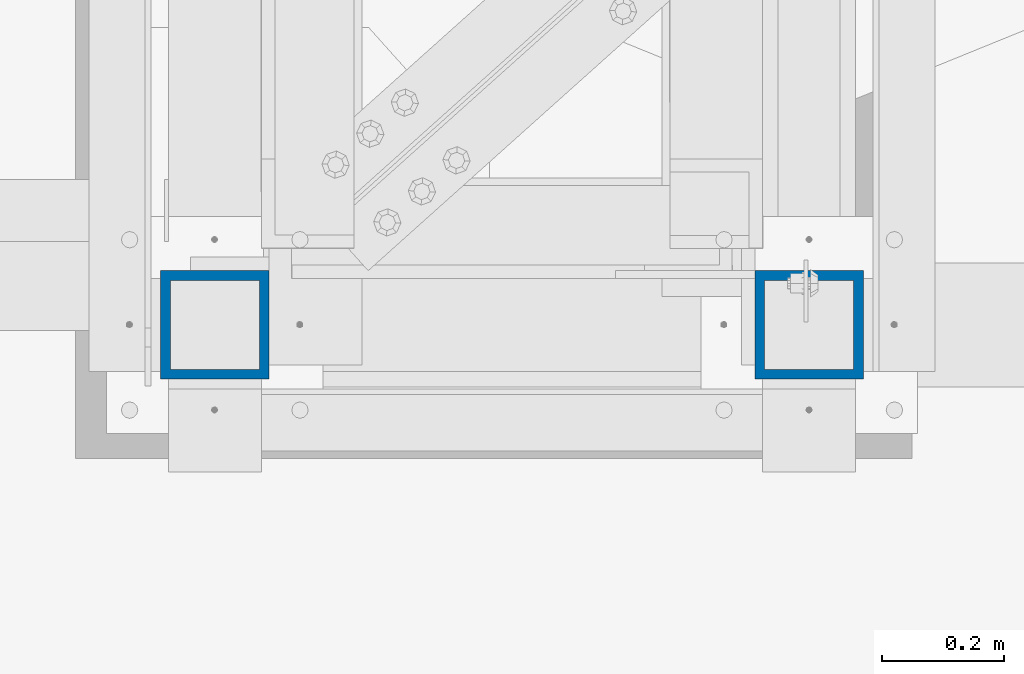
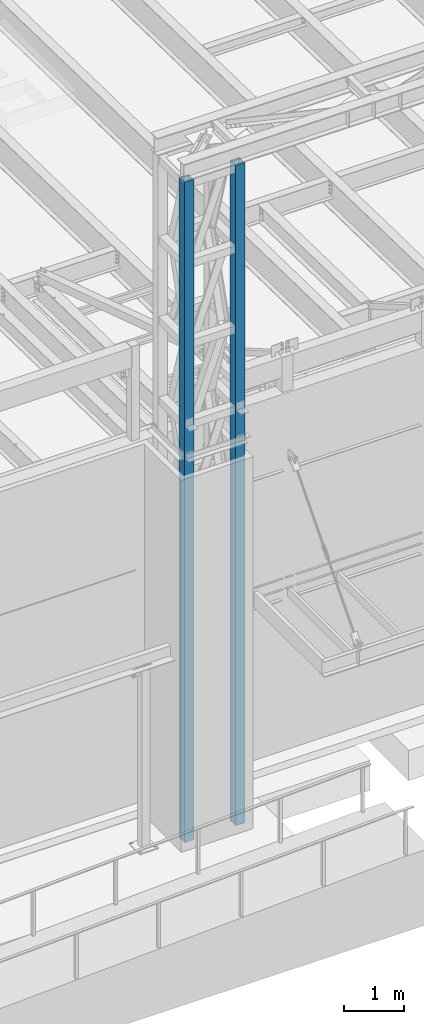
# One storey, part 889 of 1763: 2 columns, 1 element without a shape of its own.
"""IFC2X3 building model written with IfcOpenShell, lengths in millimetres."""

import ifcopenshell
import ifcopenshell.guid

model = None  # the IFC model being written
_history = None  # IfcOwnerHistory: only IFC2X3 demands one
_inside = {}  # id of a spatial element -> (the spatial element, [elements in it])
_under = {}  # id of a project, library or spatial element -> (it, [spatial elements below it])
_declared = {}  # id of a project -> (the project, [libraries it declares])
_typed = {}  # id of a type object -> (the type object, [elements of that type])
_made_of = {}  # id of a material, layer set ... -> (it, [elements and type objects made of it])


def new_model(schema):
    """Start an empty IFC model of exactly this schema.

    Asked for "IFC4X3", IfcOpenShell would pick the latest addendum, in which some entities
    have other attributes; the version numbers below select the first issue.
    IFC2X3 requires an IfcOwnerHistory on every rooted entity: one is made here for all.
    """
    global model, _history
    if schema == "IFC4X3":
        model = ifcopenshell.file(schema_version=(4, 3, 0, 0))
    else:
        model = ifcopenshell.file(schema=schema)
    _inside.clear()
    _under.clear()
    _declared.clear()
    _typed.clear()
    _made_of.clear()
    _history = None
    if model.schema == "IFC2X3":
        org = make("IfcOrganization", Name="unknown")
        user = make(
            "IfcPersonAndOrganization",
            ThePerson=make("IfcPerson", FamilyName="unknown"),
            TheOrganization=org,
        )
        app = make(
            "IfcApplication",
            ApplicationDeveloper=org,
            Version="unknown",
            ApplicationFullName="unknown",
            ApplicationIdentifier="unknown",
        )
        _history = make(
            "IfcOwnerHistory",
            OwningUser=user,
            OwningApplication=app,
            ChangeAction="ADDED",
            CreationDate=0,
        )
    return model


def make(cls, **values):
    """One entity of the class cls with the attributes given. An attribute that is None is left unset."""
    return model.create_entity(
        cls, **{name: value for name, value in values.items() if value is not None}
    )


def rooted(cls, **values):
    """An entity with a GlobalId (a new one), such as an element, a storey or a relation."""
    return make(cls, GlobalId=ifcopenshell.guid.new(), OwnerHistory=_history, **values)


def si_unit(unit_type, name, prefix=None):
    """IfcSIUnit, for example si_unit("LENGTHUNIT", "METRE", prefix="MILLI")."""
    return make("IfcSIUnit", UnitType=unit_type, Prefix=prefix, Name=name)


def assignment(units):
    """IfcUnitAssignment: the units of a project."""
    return None if units is None else make("IfcUnitAssignment", Units=units)


def point(xyz):
    """IfcCartesianPoint."""
    return None if xyz is None else make("IfcCartesianPoint", Coordinates=xyz)


def direction(xyz):
    """IfcDirection."""
    return None if xyz is None else make("IfcDirection", DirectionRatios=xyz)


def frame(location, z_axis=None, x_axis=None):
    """IfcAxis2Placement3D, a coordinate frame: its origin and axes. An axis left out is left unset."""
    return make(
        "IfcAxis2Placement3D",
        Location=point(location),
        Axis=direction(z_axis),
        RefDirection=direction(x_axis),
    )


def origin_with_axes():
    """The frame at (0, 0, 0) with the z axis (0, 0, 1) and the x axis (1, 0, 0) written out."""
    return frame((0.0, 0.0, 0.0), z_axis=(0.0, 0.0, 1.0), x_axis=(1.0, 0.0, 0.0))


def place(relative_to, where):
    """IfcLocalPlacement: puts the frame where relative to a parent placement (None: the world)."""
    return make(
        "IfcLocalPlacement", PlacementRelTo=relative_to, RelativePlacement=where
    )


def context(
    kind, dimensions, precision=None, world=None, true_north=None, identifier=None
):
    """IfcGeometricRepresentationContext, for example the 3D "Model" context."""
    return make(
        "IfcGeometricRepresentationContext",
        ContextIdentifier=identifier,
        ContextType=kind,
        CoordinateSpaceDimension=dimensions,
        Precision=precision,
        WorldCoordinateSystem=world,
        TrueNorth=true_north,
    )


def subcontext(parent, identifier, kind, view, scale=None):
    """IfcGeometricRepresentationSubContext, for example "Body" below "Model"."""
    return make(
        "IfcGeometricRepresentationSubContext",
        ContextIdentifier=identifier,
        ContextType=kind,
        ParentContext=parent,
        TargetScale=scale,
        TargetView=view,
    )


def project(units=None, contexts=None):
    """IfcProject with its units and contexts."""
    return rooted(
        "IfcProject",
        Name="project",
        RepresentationContexts=contexts,
        UnitsInContext=assignment(units),
    )


def spatial(cls, under=None, at=None, **own):
    """A site, building, storey or space (cls), placed at a placement, below another one or the project."""
    s = rooted(cls, ObjectPlacement=at, **own)
    if under is not None:
        _under.setdefault(under.id(), (under, []))[1].append(s)
    return s


def faces_of(points, faces, orient=None, outer=None):
    """IfcFace entities. A face is a list of loops; a loop is a list of indices into points, from 0.

    orient and outer hold one flag for each loop. By default every Orientation is true, the
    first loop of a face is its IfcFaceOuterBound and the others are IfcFaceBound.
    """
    made = []
    for i, loops in enumerate(faces):
        bounds = []
        for j, loop in enumerate(loops):
            is_outer = j == 0 if outer is None else outer[i][j]
            bounds.append(
                make(
                    "IfcFaceOuterBound" if is_outer else "IfcFaceBound",
                    Bound=make("IfcPolyLoop", Polygon=[points[k] for k in loop]),
                    Orientation=True if orient is None else orient[i][j],
                )
            )
        made.append(make("IfcFace", Bounds=bounds))
    return made


def faceted_brep(points, faces, orient=None, outer=None, voids=None):
    """IfcFacetedBrep: a solid bounded by flat faces; with voids (closed shells), ...WithVoids."""
    shared = [point(p) for p in points]
    hull = make("IfcClosedShell", CfsFaces=faces_of(shared, faces, orient, outer))
    if voids is None:
        return make("IfcFacetedBrep", Outer=hull)
    return make(
        "IfcFacetedBrepWithVoids",
        Outer=hull,
        Voids=[
            make(cls, CfsFaces=faces_of(shared, fs, o, b)) for cls, fs, o, b in voids
        ],
    )


def shape(context_of_items, identifier, shape_type, items):
    """IfcShapeRepresentation: the items that make up one representation, for example the "Body"."""
    return make(
        "IfcShapeRepresentation",
        ContextOfItems=context_of_items,
        RepresentationIdentifier=identifier,
        RepresentationType=shape_type,
        Items=items,
    )


def material(Name=None, Category=None):
    """IfcMaterial."""
    return make("IfcMaterial", Name=Name, Category=Category)


def made_of(thing, what):
    """Note that an element or type object is made of a material, layer set ...; save() writes the relation."""
    if what is not None:
        _made_of.setdefault(what.id(), (what, []))[1].append(thing)
    return thing


def type_object(cls, material=None, **own):
    """A type object (cls), such as IfcWallType, which elements share."""
    return made_of(rooted(cls, **own), material)


def element(
    cls,
    number,
    at=None,
    inside=None,
    cuts=None,
    type_object=None,
    material=None,
    context=None,
    identifier="Body",
    shape_type=None,
    held_by="IfcProductDefinitionShape",
    body=None,
    shapes=None,
    **own,
):
    """One element of the class cls, such as IfcWall. Its Tag is "e" and its number.

    at: its placement. inside: the storey or other place that contains it. cuts: it is an
    opening in that element (IfcRelVoidsElement). A single representation is given by context,
    identifier, shape_type and body (its items); several are given by shapes. held_by: the class
    of the entity that holds the representations. save() writes the other relations.
    """
    e = rooted(cls, Tag="e%d" % number, ObjectPlacement=at, **own)
    if body is not None:
        shapes = [shape(context, identifier, shape_type, body)]
    if shapes is not None:
        e.Representation = make(held_by, Representations=shapes)
    if inside is not None:
        _inside.setdefault(inside.id(), (inside, []))[1].append(e)
    if cuts is not None:
        rooted(
            "IfcRelVoidsElement", RelatingBuildingElement=cuts, RelatedOpeningElement=e
        )
    if type_object is not None:
        _typed.setdefault(type_object.id(), (type_object, []))[1].append(e)
    return made_of(e, material)


def aggregate(whole, parts):
    """IfcRelAggregates: a whole, such as a stair, and the parts it consists of."""
    return rooted("IfcRelAggregates", RelatingObject=whole, RelatedObjects=parts)


def save(model, path):
    """Write the relations noted so far, then the file.

    IfcRelAggregates (storeys below a building ...), IfcRelContainedInSpatialStructure (elements
    in a storey), IfcRelDefinesByType, IfcRelAssociatesMaterial and IfcRelDeclares: one each for
    every whole, place, type object, material and project.
    """
    for whole, parts in _under.values():
        aggregate(whole, parts)
    for where, things in _inside.values():
        rooted(
            "IfcRelContainedInSpatialStructure",
            RelatedElements=things,
            RelatingStructure=where,
        )
    for kind, things in _typed.values():
        rooted("IfcRelDefinesByType", RelatedObjects=things, RelatingType=kind)
    for what, things in _made_of.values():
        rooted("IfcRelAssociatesMaterial", RelatedObjects=things, RelatingMaterial=what)
    for by, libraries in _declared.values():
        rooted("IfcRelDeclares", RelatingContext=by, RelatedDefinitions=libraries)
    model.write(path)


model = new_model("IFC2X3")

# Units and contexts
model_context = context("Model", 3, precision=1e-05, world=origin_with_axes())
body_context = subcontext(model_context, "Body", "Model", "MODEL_VIEW")
ifc_project = project(units=[si_unit("LENGTHUNIT", "METRE", prefix="MILLI"), si_unit("AREAUNIT", "SQUARE_METRE"), si_unit("VOLUMEUNIT", "CUBIC_METRE"), si_unit("MASSUNIT", "GRAM", prefix="KILO"), si_unit("TIMEUNIT", "SECOND"), si_unit("PLANEANGLEUNIT", "RADIAN"), si_unit("SOLIDANGLEUNIT", "STERADIAN"), si_unit("THERMODYNAMICTEMPERATUREUNIT", "DEGREE_CELSIUS"), si_unit("LUMINOUSINTENSITYUNIT", "LUMEN")], contexts=[model_context])

# Site, building, storey
site_placement = place(None, origin_with_axes())
site = spatial("IfcSite", under=ifc_project, at=site_placement, CompositionType="ELEMENT")
building_placement = place(site_placement, origin_with_axes())
building = spatial("IfcBuilding", under=site, at=building_placement, Name="Undefined", CompositionType="ELEMENT")
storey_placement = place(building_placement, origin_with_axes())
storey = spatial("IfcBuildingStorey", under=building, at=storey_placement, Name="Undefined", CompositionType="ELEMENT", Elevation=0.0)

# Assembly, columns
assembly_placement = place(storey_placement, origin_with_axes())
assembly = element("IfcElementAssembly", 1, at=assembly_placement, inside=storey, Name="FRAME", AssemblyPlace="NOTDEFINED", PredefinedType="RIGID_FRAME")
ifc_material = material()
column_type = type_object("IfcColumnType", Name="HSS7X7X5/8", PredefinedType="NOTDEFINED")
column_1_placement = place(assembly_placement, frame((-63210.5025957005, -15452.7273151462, 5029.2), z_axis=(0.0, 1.0, 0.0), x_axis=(0.0, 0.0, 1.0)))
column_1 = element("IfcColumn", 2, at=column_1_placement, type_object=column_type, material=ifc_material, Name="COLUMN", ObjectType="HSS7X7X5/8", context=body_context, shape_type="Brep", body=[
    faceted_brep([(63.5000000000009, 73.0250000000015, -73.0249999999996), (63.5000000000009, -73.0250000000015, -73.0249999999996), (13420.725, -73.0250000000015, -73.0249999999996), (13420.725, 73.0250000000015, -73.0249999999996), (63.5000000000009, -73.0250000000015, 73.0249999999996), (13420.725, -73.0250000000015, 73.0249999999996), (63.5000000000009, 73.0250000000015, 73.0249999999996), (13420.725, 73.0250000000015, 73.0249999999996), (63.5000000000009, 88.9000000000015, -88.8999999999996), (63.5000000000009, 88.9000000000015, 88.8999999999996), (13420.725, 88.9000000000015, 88.8999999999996), (13420.725, 88.9000000000015, -88.8999999999996), (63.5000000000009, -88.9000000000015, 88.8999999999996), (13420.725, -88.9000000000015, 88.8999999999996), (63.5000000000009, -88.9000000000015, -88.8999999999996), (13420.725, -88.9000000000015, -88.8999999999996)], [[[0, 1, 2, 3]], [[1, 4, 5, 2]], [[4, 6, 7, 5]], [[6, 0, 3, 7]], [[8, 9, 10, 11]], [[9, 12, 13, 10]], [[12, 14, 15, 13]], [[14, 8, 11, 15]], [[13, 15, 11, 10], [5, 7, 3, 2]], [[14, 12, 9, 8], [6, 4, 1, 0]]]),
])
column_2_placement = place(assembly_placement, frame((-64185.2277910131, -15452.7273151462, 5029.2), z_axis=(0.0, 1.0, 0.0), x_axis=(0.0, 0.0, 1.0)))
column_2 = element("IfcColumn", 3, at=column_2_placement, type_object=column_type, material=ifc_material, Name="FRAME", ObjectType="HSS7X7X5/8", context=body_context, shape_type="Brep", body=[
    faceted_brep([(63.5000000000009, 73.0250000000015, -73.0249999999996), (63.5000000000009, -73.0250000000015, -73.0249999999996), (13420.725, -73.0250000000015, -73.0249999999996), (13420.725, 73.0250000000015, -73.0249999999996), (63.5000000000009, -73.0250000000015, 73.0249999999996), (13420.725, -73.0250000000015, 73.0249999999996), (63.5000000000009, 73.0250000000015, 73.0249999999996), (13420.725, 73.0250000000015, 73.0249999999996), (63.5000000000009, 88.9000000000015, -88.8999999999996), (63.5000000000009, 88.9000000000015, 88.8999999999996), (13420.725, 88.9000000000015, 88.8999999999996), (13420.725, 88.9000000000015, -88.8999999999996), (63.5000000000009, -88.9000000000015, 88.8999999999996), (13420.725, -88.9000000000015, 88.8999999999996), (63.5000000000009, -88.9000000000015, -88.8999999999996), (13420.725, -88.9000000000015, -88.8999999999996)], [[[0, 1, 2, 3]], [[1, 4, 5, 2]], [[4, 6, 7, 5]], [[6, 0, 3, 7]], [[8, 9, 10, 11]], [[9, 12, 13, 10]], [[12, 14, 15, 13]], [[14, 8, 11, 15]], [[13, 15, 11, 10], [5, 7, 3, 2]], [[14, 12, 9, 8], [6, 4, 1, 0]]]),
])
aggregate(assembly, [column_1, column_2])

save(model, "model.ifc")
